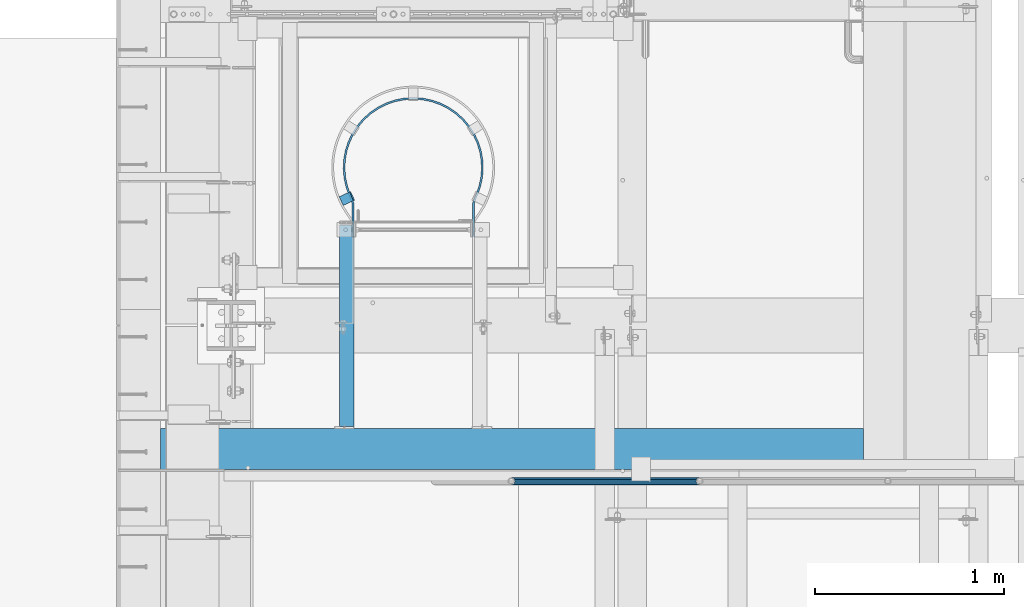
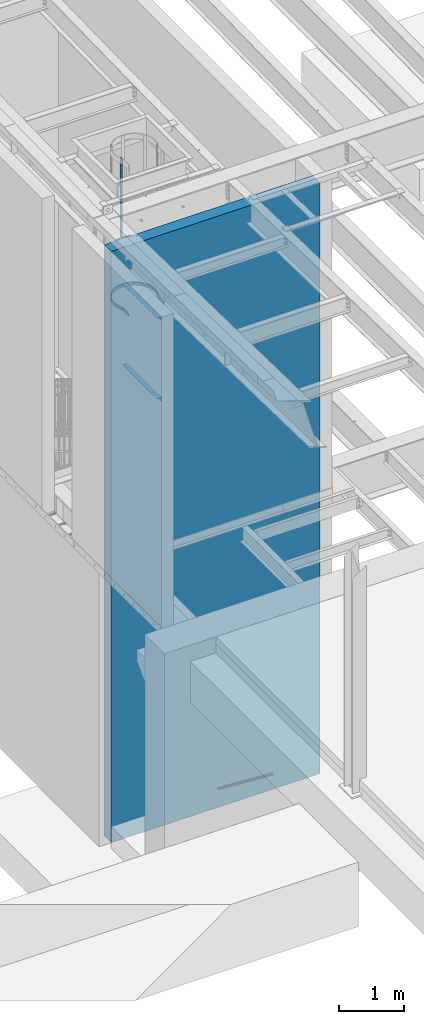
# One storey, part 1077 of 1763: 7 beams, 3 elements without a shape of their own.
"""IFC2X3 building model written with IfcOpenShell, lengths in millimetres."""

from ifc_helpers import new_model, si_unit, frame, origin_with_axes, place, context, subcontext, project, spatial, faceted_brep, material, type_object, element, aggregate, save


model = new_model("IFC2X3")

# Units and contexts
model_context = context("Model", 3, precision=1e-05, world=origin_with_axes())
body_context = subcontext(model_context, "Body", "Model", "MODEL_VIEW")
ifc_project = project(units=[si_unit("LENGTHUNIT", "METRE", prefix="MILLI"), si_unit("AREAUNIT", "SQUARE_METRE"), si_unit("VOLUMEUNIT", "CUBIC_METRE"), si_unit("MASSUNIT", "GRAM", prefix="KILO"), si_unit("TIMEUNIT", "SECOND"), si_unit("PLANEANGLEUNIT", "RADIAN"), si_unit("SOLIDANGLEUNIT", "STERADIAN"), si_unit("THERMODYNAMICTEMPERATUREUNIT", "DEGREE_CELSIUS"), si_unit("LUMINOUSINTENSITYUNIT", "LUMEN")], contexts=[model_context])

# Site, building, storey
site_placement = place(None, origin_with_axes())
site = spatial("IfcSite", under=ifc_project, at=site_placement, CompositionType="ELEMENT")
building_placement = place(site_placement, origin_with_axes())
building = spatial("IfcBuilding", under=site, at=building_placement, Name="Undefined", CompositionType="ELEMENT")
storey_placement = place(building_placement, origin_with_axes())
storey = spatial("IfcBuildingStorey", under=building, at=storey_placement, Name="Undefined", CompositionType="ELEMENT", Elevation=0.0)

# Assembly, beam
assembly_1_placement = place(storey_placement, origin_with_axes())
assembly_1 = element("IfcElementAssembly", 1, at=assembly_1_placement, inside=storey, Name="GUARDRAIL", AssemblyPlace="NOTDEFINED", PredefinedType="RIGID_FRAME")
ifc_material_1 = material()
beam_type_1 = type_object("IfcBeamType", PredefinedType="NOTDEFINED")
beam_1_placement = place(assembly_1_placement, frame((-84891.4958692839, 29197.2999999971, 342.725435582883), z_axis=(0.0, -1.0, 0.0), x_axis=(-0.997891522550524, 0.0, 0.0649038459707657)))
beam_1 = element("IfcBeam", 2, at=beam_1_placement, type_object=beam_type_1, material=ifc_material_1, Name="GUARDRAIL", context=body_context, shape_type="Brep", body=[
    faceted_brep([(1000.15019855548, 2.81943357549608e-11, -19.0499999999993), (989.985557506108, 9.5250000000251, -16.4977839420935), (991.224588240293, -9.52499999997053, -16.4977839420935), (982.257505670044, 13.3082123799786, 7.68349999999919), (980.060462398702, 15.3670000000229, 0.0), (979.820916456767, 19.050000000022, 0.0), (982.544523817283, 16.4977839421163, 9.52500000000146), (982.87174965936, 11.46671237998, 9.52500000000146), (982.87174965936, 11.46671237998, -9.52500000000146), (982.544523817283, 16.4977839421163, -9.52500000000146), (982.257505670044, 13.3082123799786, -7.68349999999919), (986.909019565966, 7.68350000002556, -13.3082123799541), (989.47189966141, 2.81943357549608e-11, -15.3669999999984), (987.908504358144, -7.68349999997099, -13.3082123799541), (984.363362158969, -11.4667123799254, -9.52500000000146), (984.690588001031, -16.4977839420635, -9.52500000000146), (983.988664111486, -13.3082123799259, -7.68349999999919), (982.059431983173, -15.3669999999702, 0.0), (982.298977925122, -19.0499999999693, 0.0), (983.988664111486, -13.3082123799259, 7.68349999999919), (984.363362158969, -11.4667123799254, 9.52500000000146), (984.690588001031, -16.4977839420635, 9.52500000000146), (1000.15019855546, 2.72848410531878e-11, 19.0499999999993), (991.224588240293, -9.52499999997053, 16.4977839420935), (989.985557506108, 9.5250000000251, 16.4977839420935), (987.908504358144, -7.68349999997099, 13.3082123799541), (989.47189966141, 2.72848410531878e-11, 15.3669999999984), (986.909019565966, 7.68350000002465, 13.3082123799541), (8.92561031517107, 9.52499999999873, -16.4977839420935), (15.4596105544624, 16.4977839420917, -9.52500000000146), (17.8512206303712, 19.0499999999975, 0.0), (18.0907665723062, 15.3669999999984, 0.0), (15.7868363965099, 11.4667123799545, -9.52500000000146), (16.1615344449092, 13.3082123799541, -7.68349999999919), (16.1615344449092, 13.3082123799541, 7.68349999999919), (15.7868363965099, 11.4667123799545, 9.52500000000146), (15.4596105544624, 16.4977839420917, 9.52500000000146), (8.92561031517107, 9.52499999999873, 16.4977839420935), (1.45519152283669e-11, 1.81898940354586e-12, 19.0499999999993), (10.1646410493704, -9.524999999996, 16.4977839420935), (10.1646410493704, -9.52499999999509, -16.4977839420935), (1.45519152283669e-11, 1.81898940354586e-12, -19.0499999999993), (17.6056747381954, -16.4977839420881, -9.52500000000146), (20.3292820987263, -19.0499999999938, 0.0), (17.6056747381954, -16.4977839420881, 9.52500000000146), (17.2784488961188, -11.4667123799518, -9.52500000000146), (13.2411789904436, -7.68349999999555, -13.3082123799541), (10.6782988949999, 1.81898940354586e-12, -15.3669999999984), (12.2416941982665, 7.68350000000009, -13.3082123799541), (20.0897361567768, -15.3669999999947, 0.0), (17.8926928863511, -13.3082123799504, -7.68349999999919), (17.2784488961188, -11.4667123799518, 9.52500000000146), (17.8926928863511, -13.3082123799504, 7.68349999999919), (12.2416941982665, 7.68350000000009, 13.3082123799541), (10.6782988949999, 1.81898940354586e-12, 15.3669999999984), (13.2411789904436, -7.68349999999646, 13.3082123799541)], [[[0, 1, 2]], [[3, 4, 5, 6, 7]], [[8, 9, 5, 4, 10]], [[2, 1, 9, 8, 11, 12, 13, 14, 15]], [[15, 14, 16, 17, 18]], [[18, 17, 19, 20, 21]], [[22, 23, 24]], [[21, 20, 25, 26, 27, 7, 6, 24, 23]], [[9, 1, 28, 29]], [[5, 9, 29, 30]], [[31, 30, 29, 32, 33]], [[34, 35, 36, 30, 31]], [[6, 5, 30, 36]], [[24, 6, 36, 37]], [[22, 24, 37, 38]], [[38, 37, 39]], [[0, 2, 40, 41]], [[2, 15, 42, 40]], [[15, 18, 43, 42]], [[18, 21, 44, 43]], [[21, 23, 39, 44]], [[23, 22, 38, 39]], [[1, 0, 41, 28]], [[40, 28, 41]], [[42, 45, 46, 47, 48, 32, 29, 28, 40]], [[43, 49, 50, 45, 42]], [[44, 51, 52, 49, 43]], [[39, 37, 36, 35, 53, 54, 55, 51, 44]], [[26, 25, 55, 54]], [[55, 25, 20, 19, 52, 51]], [[19, 17, 49, 52]], [[17, 16, 50, 49]], [[16, 14, 13, 46, 45, 50]], [[13, 12, 47, 46]], [[12, 11, 48, 47]], [[48, 11, 8, 10, 33, 32]], [[10, 4, 31, 33]], [[4, 3, 34, 31]], [[3, 7, 27, 53, 35, 34]], [[27, 26, 54, 53]]]),
])
aggregate(assembly_1, [beam_1])

# Assembly, beams
assembly_2_placement = place(storey_placement, origin_with_axes())
assembly_2 = element("IfcElementAssembly", 3, at=assembly_2_placement, inside=storey, Name="LADDER", AssemblyPlace="NOTDEFINED", PredefinedType="RIGID_FRAME")
ifc_material_2 = material(Name="STEEL/A36")
beam_type_2 = type_object("IfcBeamType", Name="L3X3X1/4", PredefinedType="NOTDEFINED")
beam_2_placement = place(assembly_2_placement, frame((-86762.6624669171, 30556.2000060747, 9410.7), z_axis=(-1.0, 0.0, 0.0), x_axis=(0.0, -1.0, 0.0)))
beam_2 = element("IfcBeam", 4, at=beam_2_placement, type_object=beam_type_2, material=ifc_material_2, Name="ANGLE", ObjectType="L3X3X1/4", context=body_context, shape_type="Brep", body=[
    faceted_brep([(0.0, 38.0999999999985, -38.1000000000004), (0.0, 38.0999999999985, 38.1000000000004), (1069.97500607761, 38.1000000000004, 38.1000000000058), (1069.97500607761, 38.1000000000004, -38.1000000000058), (0.0, 31.75, 38.1000000000058), (1069.97500607761, 31.75, 38.1000000000058), (0.0, 31.75, -31.75), (1069.97500607761, 31.75, -31.75), (0.0, -38.1000000000004, -31.75), (1069.97500607761, -38.1000000000004, -31.75), (0.0, -38.0999999999985, -38.1000000000004), (1069.97500607761, -38.1000000000004, -38.1000000000058)], [[[0, 1, 2, 3]], [[1, 4, 5, 2]], [[4, 6, 7, 5]], [[6, 8, 9, 7]], [[8, 10, 11, 9]], [[10, 0, 3, 11]], [[5, 7, 9, 11, 3, 2]], [[10, 8, 6, 4, 1, 0]]]),
])
beam_3_placement = place(assembly_2_placement, frame((-86762.6624669171, 30556.2000060747, 7886.70000005696), z_axis=(-1.0, 0.0, 0.0), x_axis=(0.0, -1.0, 0.0)))
beam_3 = element("IfcBeam", 5, at=beam_3_placement, type_object=beam_type_2, material=ifc_material_2, Name="ANGLE", ObjectType="L3X3X1/4", context=body_context, shape_type="Brep", body=[
    faceted_brep([(0.0, 38.0999999999985, -38.1000000000004), (0.0, 38.0999999999985, 38.1000000000004), (1069.97500607761, 38.1000000000004, 38.1000000000058), (1069.97500607761, 38.1000000000004, -38.1000000000058), (0.0, 31.75, 38.1000000000058), (1069.97500607761, 31.75, 38.1000000000058), (0.0, 31.75, -31.75), (1069.97500607761, 31.75, -31.75), (0.0, -38.1000000000004, -31.75), (1069.97500607761, -38.1000000000004, -31.75), (0.0, -38.0999999999985, -38.1000000000004), (1069.97500607761, -38.1000000000004, -38.1000000000058)], [[[0, 1, 2, 3]], [[1, 4, 5, 2]], [[4, 6, 7, 5]], [[6, 8, 9, 7]], [[8, 10, 11, 9]], [[10, 0, 3, 11]], [[5, 7, 9, 11, 3, 2]], [[10, 8, 6, 4, 1, 0]]]),
])
beam_type_3 = type_object("IfcBeamType", PredefinedType="NOTDEFINED")
beam_4_placement = place(assembly_2_placement, frame((-86789.3779025073, 30684.2038212696, 7620.0), z_axis=(0.422618261967727, -0.906307786930785, 0.0), x_axis=(0.0, 0.0, 1.0)))
beam_4 = element("IfcBeam", 6, at=beam_4_placement, type_object=beam_type_3, material=ifc_material_2, Name="PLATE", context=body_context, shape_type="Brep", body=[
    faceted_brep([(0.0, -3.17500000017753, -25.4000000001233), (0.0, -3.17499999987194, 25.4000000001051), (0.0, 3.17500000014843, 25.4000000001197), (0.0, 3.17499999984284, -25.4000000001088), (76.1999969380622, 3.17500000014843, 25.4000000001197), (76.1999969380695, 3.17499999984284, -25.4000000001088), (76.0331158036188, -3.17500000017753, -25.4000000001197), (76.0331158036115, -3.17499999987194, 25.4000000001051), (1225.55004882846, -57.2777259409777, 25.400000000287), (1225.55004882847, -57.2777259412833, -25.3999999999487), (1225.38316769402, -63.6277259413182, -25.3999999999633), (1225.38316769401, -63.6277259410126, 25.4000000002725), (4092.07739257812, -57.2777259409631, 25.4000000002798), (4092.07739257812, -57.2777259412833, -25.399999999956), (4092.07739257812, -63.6277259410126, 25.4000000002652), (4092.07739257812, -63.6277259413182, -25.3999999999705)], [[[0, 1, 2, 3]], [[3, 2, 4, 5]], [[1, 0, 6, 7]], [[5, 4, 8, 9]], [[7, 6, 10, 11]], [[9, 8, 12, 13]], [[8, 4, 2, 1, 7, 11, 14, 12]], [[11, 10, 15, 14]], [[10, 6, 0, 3, 5, 9, 13, 15]], [[14, 15, 13, 12]]]),
])
beam_type_4 = type_object("IfcBeamType", PredefinedType="NOTDEFINED")
beam_5_placement = place(assembly_2_placement, frame((-86091.1497736991, 30492.7, 9761.28873111828), z_axis=(0.0, 0.0, 1.0), x_axis=(0.0, 1.0, 0.0)))
beam_5 = element("IfcBeam", 7, at=beam_5_placement, type_object=beam_type_4, material=ifc_material_2, Name="PLATE", context=body_context, shape_type="Brep", body=[
    faceted_brep([(0.0, -4.76249999999709, -31.75), (0.0, -4.76250000000073, 31.75), (0.0, 4.76250000000073, 31.75), (0.0, 4.76249999999709, -31.75), (178.996850182604, 4.76249999999709, 31.75), (178.996850182604, 4.76249999999709, -31.75), (177.198920081068, -4.76249999999709, -31.75), (177.198920081068, -4.76249999999709, 31.75), (223.923672469686, -12.8248261728149, 31.75), (223.923672469686, -12.8248261728149, -31.75), (220.301876254001, -21.6358444885554, -31.75), (220.301876254001, -21.6358444885554, 31.75), (225.062862920662, -13.315718922473, 31.75), (225.062862920662, -13.315718922473, -31.75), (221.293479549164, -22.0631399137492, -31.75), (221.293479549164, -22.0631399137492, 31.75), (268.797622331076, -28.9179700700479, 31.75), (268.797622331076, -28.9179700700479, -31.75), (266.179279316701, -38.0760214380571, -31.75), (266.179279316701, -38.0760214380571, 31.75), (312.745907862791, -48.2099496661976, -31.75), (312.745907862791, -48.2099496661976, 31.75), (314.170107762209, -38.7920263469859, 31.75), (314.170241653486, -38.7920465962816, -31.75), (361.121282329259, -42.7913046950562, 31.75), (361.121282318767, -42.7913046948524, -31.75), (360.932367573077, -52.3144310837524, -31.75), (360.932367573077, -52.3144310837524, 31.75), (408.553266824139, -40.6172059538658, 31.75), (408.55326734237, -40.6172058958764, -31.75), (409.612565695392, -50.0831190583413, -31.75), (409.612565695392, -50.0831190583413, 31.75), (455.29255648837, -32.2529272571555, 31.75), (455.292556022912, -32.2529273724067, -31.75), (457.581833160064, -41.4987283214577, -31.75), (457.581833160064, -41.4987283214577, 31.75), (500.534787634006, -17.8424056936346, 31.75), (500.534787766108, -17.8424056417862, -31.75), (504.014650842557, -26.7089820932306, -31.75), (504.014650842557, -26.7089820932306, 31.75), (543.501358126799, 2.36636306563742, 31.75), (543.501358463509, 2.36636325190193, -31.75), (548.111923123197, -5.96840240281017, -31.75), (548.111923123197, -5.96840240281017, 31.75), (584.009198027747, 28.437626318133, 31.75), (584.009196713676, 28.4376253428782, -31.75), (589.685748261316, 20.7889399965643, -31.75), (589.685748261316, 20.7889399965643, 31.75), (620.696023637076, 59.6572758920083, 31.75), (620.696025797544, 59.6572779939015, -31.75), (627.338033980115, 52.8301737539878, -31.75), (627.338033980115, 52.8301737539878, 31.75), (652.912087062563, 95.4723277354788, 31.75), (652.91208579253, 95.4723261190084, -31.75), (660.401877781187, 89.5877155994822, -31.75), (660.401877781187, 89.5877155994822, 31.75), (680.086755434721, 135.248364146639, 31.75), (680.086754505715, 135.248362571074, -31.75), (688.291662534022, 130.410479847502, -31.75), (688.291662534022, 130.410479847502, 31.75), (701.738563283165, 178.280798617299, 31.75), (701.73856488548, 178.280802411682, -31.75), (710.513267771523, 174.575372037012, -31.75), (710.513267771523, 174.575372037012, 31.75), (717.484088221368, 223.807419031116, 31.75), (717.484087259192, 223.80741550494, -31.75), (726.673138341132, 221.300033361462, -31.75), (726.673138341132, 221.300033361462, 31.75), (727.044327443258, 271.021749271633, 31.75), (727.044327941214, 271.021752988236, -31.75), (736.484969431742, 269.756876216648, -31.75), (736.484969431742, 269.756876216648, 31.75), (730.250012207038, 319.087498404828, 31.75), (730.250012207031, 319.087495313172, -31.75), (739.775012207032, 319.087489388141, -31.75), (739.775012207032, 319.087489388141, 31.75), (727.044328675405, 367.153259842584, 31.75), (727.044328513592, 367.153261050305, -31.75), (736.484968199595, 368.418151290229, -31.75), (736.484968199595, 368.418151290229, 31.75), (717.484085293047, 414.367594752388, 31.75), (717.484085562104, 414.367593766336, -31.75), (726.673141269457, 416.87495895855, -31.75), (726.673141269457, 416.87495895855, 31.75), (701.738568815384, 459.894191333835, 31.75), (701.738567727607, 459.894193909757, -31.75), (710.513262239299, 463.599644115384, -31.75), (710.513262239299, 463.599644115384, 31.75), (680.086748702986, 502.926650321984, 31.75), (680.086750557224, 502.926647177228, -31.75), (688.29166926576, 507.764511787405, -31.75), (688.29166926576, 507.764511787405, 31.75), (652.912093282088, 542.702644512043, 31.75), (652.912090596754, 542.702647929866, -31.75), (660.401871561658, 548.58727248013, -31.75), (660.401871561658, 548.58727248013, 31.75), (620.696019913037, 578.51772696813, 31.75), (620.696024247423, 578.517722751247, -31.75), (627.338037704154, 585.344821859995, -31.75), (627.338037704154, 585.344821859995, 31.75), (584.009197168081, 609.737364020199, 31.75), (584.009193942664, 609.737366413974, -31.75), (589.685749120978, 617.386049065753, -31.75), (589.685749120978, 617.386049065753, 31.75), (543.501362367231, 635.808628103681, 31.75), (543.501361835584, 635.808628397775, -31.75), (548.111918882772, 644.143398263506, -31.75), (548.111918882772, 644.143398263506, 31.75), (500.534784456919, 656.017396640862, 31.75), (500.534786494096, 656.017395841336, -31.75), (504.014654019651, 664.883970546623, -31.75), (504.014654019651, 664.883970546623, 31.75), (455.292552670799, 670.427942698254, 31.75), (455.292552716117, 670.427942687034, -31.75), (457.581836977639, 679.673741872059, -31.75), (457.581836977639, 679.673741872059, 31.75), (408.553277115458, 678.792188780484, 31.75), (408.553273513717, 678.792189183543, -31.75), (409.61255540407, 688.258104188266, -31.75), (409.61255540407, 688.258104188266, 31.75), (361.121277097478, 680.966280940163, 31.75), (361.12128097919, 680.966281017158, -31.75), (360.932372804862, 690.489407536414, -31.75), (360.932372804862, 690.489407536414, 31.75), (314.170242988643, 676.96702314711, 31.75), (314.170241809003, 676.967022968674, -31.75), (312.745772636365, 686.384905563842, -31.75), (312.745772636365, 686.384905563842, 31.75), (268.136629496974, 666.902248529776, 31.75), (268.136630694469, 666.902248874627, -31.75), (265.500760639741, 676.055271001474, -31.75), (265.500760639741, 676.055271001474, 31.75), (225.062605304862, 651.49063320244, 31.75), (225.062857896504, 651.490742038819, -31.75), (221.29373196304, 660.238273954848, -31.75), (221.29373196304, 660.238273954848, 31.75), (223.92367006966, 650.999851168279, 31.75), (223.92367006966, 650.999851168279, -31.75), (220.301873029875, 659.81086903195, -31.75), (220.301873029875, 659.81086903195, 31.75), (178.996852032531, 633.412487792972, 31.75), (178.996852032531, 633.412487792972, -31.75), (177.198918231141, 642.937487792966, -31.75), (177.198918231141, 642.937487792966, 31.75), (0.0, 633.412487792972, 31.75), (0.0, 633.412487792972, -31.75), (0.0, 642.937487792966, 31.75), (0.0, 642.937487792966, -31.75)], [[[0, 1, 2, 3]], [[3, 2, 4, 5]], [[1, 0, 6, 7]], [[5, 4, 8, 9]], [[7, 6, 10, 11]], [[9, 8, 12, 13]], [[11, 10, 14, 15]], [[13, 12, 16, 17]], [[15, 14, 18, 19]], [[18, 20, 21, 19]], [[16, 22, 23, 17]], [[23, 22, 24, 25]], [[21, 20, 26, 27]], [[25, 24, 28, 29]], [[27, 26, 30, 31]], [[29, 28, 32, 33]], [[31, 30, 34, 35]], [[33, 32, 36, 37]], [[35, 34, 38, 39]], [[37, 36, 40, 41]], [[39, 38, 42, 43]], [[41, 40, 44, 45]], [[43, 42, 46, 47]], [[45, 44, 48, 49]], [[47, 46, 50, 51]], [[49, 48, 52, 53]], [[51, 50, 54, 55]], [[53, 52, 56, 57]], [[55, 54, 58, 59]], [[57, 56, 60, 61]], [[59, 58, 62, 63]], [[61, 60, 64, 65]], [[63, 62, 66, 67]], [[65, 64, 68, 69]], [[67, 66, 70, 71]], [[69, 68, 72, 73]], [[71, 70, 74, 75]], [[73, 72, 76, 77]], [[75, 74, 78, 79]], [[77, 76, 80, 81]], [[79, 78, 82, 83]], [[81, 80, 84, 85]], [[83, 82, 86, 87]], [[85, 84, 88, 89]], [[87, 86, 90, 91]], [[89, 88, 92, 93]], [[91, 90, 94, 95]], [[93, 92, 96, 97]], [[95, 94, 98, 99]], [[97, 96, 100, 101]], [[99, 98, 102, 103]], [[101, 100, 104, 105]], [[103, 102, 106, 107]], [[105, 104, 108, 109]], [[107, 106, 110, 111]], [[109, 108, 112, 113]], [[111, 110, 114, 115]], [[113, 112, 116, 117]], [[115, 114, 118, 119]], [[117, 116, 120, 121]], [[119, 118, 122, 123]], [[121, 120, 124, 125]], [[123, 122, 126, 127]], [[125, 124, 128, 129]], [[127, 126, 130, 131]], [[129, 128, 132, 133]], [[131, 130, 134, 135]], [[133, 132, 136, 137]], [[135, 134, 138, 139]], [[137, 136, 140, 141]], [[139, 138, 142, 143]], [[141, 140, 144, 145]], [[140, 136, 132, 128, 124, 120, 116, 112, 108, 104, 100, 96, 92, 88, 84, 80, 76, 72, 68, 64, 60, 56, 52, 48, 44, 40, 36, 32, 28, 24, 22, 16, 12, 8, 4, 2, 1, 7, 11, 15, 19, 21, 27, 31, 35, 39, 43, 47, 51, 55, 59, 63, 67, 71, 75, 79, 83, 87, 91, 95, 99, 103, 107, 111, 115, 119, 123, 127, 131, 135, 139, 143, 146, 144]], [[143, 142, 147, 146]], [[142, 138, 134, 130, 126, 122, 118, 114, 110, 106, 102, 98, 94, 90, 86, 82, 78, 74, 70, 66, 62, 58, 54, 50, 46, 42, 38, 34, 30, 26, 20, 18, 14, 10, 6, 0, 3, 5, 9, 13, 17, 23, 25, 29, 33, 37, 41, 45, 49, 53, 57, 61, 65, 69, 73, 77, 81, 85, 89, 93, 97, 101, 105, 109, 113, 117, 121, 125, 129, 133, 137, 141, 145, 147]], [[146, 147, 145, 144]]]),
])
beam_6_placement = place(assembly_2_placement, frame((-86091.1497736991, 30492.7, 8877.3), z_axis=(0.0, 0.0, 1.0), x_axis=(0.0, 1.0, 0.0)))
beam_6 = element("IfcBeam", 8, at=beam_6_placement, type_object=beam_type_4, material=ifc_material_2, Name="PLATE", context=body_context, shape_type="Brep", body=[
    faceted_brep([(0.0, -4.76249999999709, -31.75), (0.0, -4.76250000000073, 31.75), (0.0, 4.76250000000073, 31.75), (0.0, 4.76249999999709, -31.75), (178.996850182604, 4.76249999999709, 31.75), (178.996850182604, 4.76249999999709, -31.75), (177.198920081068, -4.76249999999709, -31.75), (177.198920081068, -4.76249999999709, 31.75), (223.923672469686, -12.8248261728149, 31.75), (223.923672469686, -12.8248261728149, -31.75), (220.301876254001, -21.6358444885554, -31.75), (220.301876254001, -21.6358444885554, 31.75), (225.062862920662, -13.315718922473, 31.75), (225.062862920662, -13.315718922473, -31.75), (221.293479549164, -22.0631399137492, -31.75), (221.293479549164, -22.0631399137492, 31.75), (268.797622331076, -28.9179700700479, 31.75), (268.797622331076, -28.9179700700479, -31.75), (266.179279316701, -38.0760214380571, -31.75), (266.179279316701, -38.0760214380571, 31.75), (312.745907862791, -48.2099496661976, -31.75), (312.745907862791, -48.2099496661976, 31.75), (314.170107762209, -38.7920263469859, 31.75), (314.170241653486, -38.7920465962816, -31.75), (361.121282329259, -42.7913046950562, 31.75), (361.121282318767, -42.7913046948524, -31.75), (360.932367573077, -52.3144310837524, -31.75), (360.932367573077, -52.3144310837524, 31.75), (408.553266824139, -40.6172059538658, 31.75), (408.55326734237, -40.6172058958764, -31.75), (409.612565695392, -50.0831190583413, -31.75), (409.612565695392, -50.0831190583413, 31.75), (455.29255648837, -32.2529272571555, 31.75), (455.292556022912, -32.2529273724067, -31.75), (457.581833160064, -41.4987283214577, -31.75), (457.581833160064, -41.4987283214577, 31.75), (500.534787634006, -17.8424056936346, 31.75), (500.534787766108, -17.8424056417862, -31.75), (504.014650842557, -26.7089820932306, -31.75), (504.014650842557, -26.7089820932306, 31.75), (543.501358126799, 2.36636306563742, 31.75), (543.501358463509, 2.36636325190193, -31.75), (548.111923123197, -5.96840240281017, -31.75), (548.111923123197, -5.96840240281017, 31.75), (584.009198027747, 28.437626318133, 31.75), (584.009196713676, 28.4376253428782, -31.75), (589.685748261316, 20.7889399965643, -31.75), (589.685748261316, 20.7889399965643, 31.75), (620.696023637076, 59.6572758920083, 31.75), (620.696025797544, 59.6572779939015, -31.75), (627.338033980115, 52.8301737539878, -31.75), (627.338033980115, 52.8301737539878, 31.75), (652.912087062563, 95.4723277354788, 31.75), (652.91208579253, 95.4723261190084, -31.75), (660.401877781187, 89.5877155994822, -31.75), (660.401877781187, 89.5877155994822, 31.75), (680.086755434721, 135.248364146639, 31.75), (680.086754505715, 135.248362571074, -31.75), (688.291662534022, 130.410479847502, -31.75), (688.291662534022, 130.410479847502, 31.75), (701.738563283165, 178.280798617299, 31.75), (701.73856488548, 178.280802411682, -31.75), (710.513267771523, 174.575372037012, -31.75), (710.513267771523, 174.575372037012, 31.75), (717.484088221368, 223.807419031116, 31.75), (717.484087259192, 223.80741550494, -31.75), (726.673138341132, 221.300033361462, -31.75), (726.673138341132, 221.300033361462, 31.75), (727.044327443258, 271.021749271633, 31.75), (727.044327941214, 271.021752988236, -31.75), (736.484969431742, 269.756876216648, -31.75), (736.484969431742, 269.756876216648, 31.75), (730.250012207038, 319.087498404828, 31.75), (730.250012207031, 319.087495313172, -31.75), (739.775012207032, 319.087489388141, -31.75), (739.775012207032, 319.087489388141, 31.75), (727.044328675405, 367.153259842584, 31.75), (727.044328513592, 367.153261050305, -31.75), (736.484968199595, 368.418151290229, -31.75), (736.484968199595, 368.418151290229, 31.75), (717.484085293047, 414.367594752388, 31.75), (717.484085562104, 414.367593766336, -31.75), (726.673141269457, 416.87495895855, -31.75), (726.673141269457, 416.87495895855, 31.75), (701.738568815384, 459.894191333835, 31.75), (701.738567727607, 459.894193909757, -31.75), (710.513262239299, 463.599644115384, -31.75), (710.513262239299, 463.599644115384, 31.75), (680.086748702986, 502.926650321984, 31.75), (680.086750557224, 502.926647177228, -31.75), (688.29166926576, 507.764511787405, -31.75), (688.29166926576, 507.764511787405, 31.75), (652.912093282088, 542.702644512043, 31.75), (652.912090596754, 542.702647929866, -31.75), (660.401871561658, 548.58727248013, -31.75), (660.401871561658, 548.58727248013, 31.75), (620.696019913037, 578.51772696813, 31.75), (620.696024247423, 578.517722751247, -31.75), (627.338037704154, 585.344821859995, -31.75), (627.338037704154, 585.344821859995, 31.75), (584.009197168081, 609.737364020199, 31.75), (584.009193942664, 609.737366413974, -31.75), (589.685749120978, 617.386049065753, -31.75), (589.685749120978, 617.386049065753, 31.75), (543.501362367231, 635.808628103681, 31.75), (543.501361835584, 635.808628397775, -31.75), (548.111918882772, 644.143398263506, -31.75), (548.111918882772, 644.143398263506, 31.75), (500.534784456919, 656.017396640862, 31.75), (500.534786494096, 656.017395841336, -31.75), (504.014654019651, 664.883970546623, -31.75), (504.014654019651, 664.883970546623, 31.75), (455.292552670799, 670.427942698254, 31.75), (455.292552716117, 670.427942687034, -31.75), (457.581836977639, 679.673741872059, -31.75), (457.581836977639, 679.673741872059, 31.75), (408.553277115458, 678.792188780484, 31.75), (408.553273513717, 678.792189183543, -31.75), (409.61255540407, 688.258104188266, -31.75), (409.61255540407, 688.258104188266, 31.75), (361.121277097478, 680.966280940163, 31.75), (361.12128097919, 680.966281017158, -31.75), (360.932372804862, 690.489407536414, -31.75), (360.932372804862, 690.489407536414, 31.75), (314.170242988643, 676.96702314711, 31.75), (314.170241809003, 676.967022968674, -31.75), (312.745772636365, 686.384905563842, -31.75), (312.745772636365, 686.384905563842, 31.75), (268.136629496974, 666.902248529776, 31.75), (268.136630694469, 666.902248874627, -31.75), (265.500760639741, 676.055271001474, -31.75), (265.500760639741, 676.055271001474, 31.75), (225.062605304862, 651.49063320244, 31.75), (225.062857896504, 651.490742038819, -31.75), (221.29373196304, 660.238273954848, -31.75), (221.29373196304, 660.238273954848, 31.75), (223.92367006966, 650.999851168279, 31.75), (223.92367006966, 650.999851168279, -31.75), (220.301873029875, 659.81086903195, -31.75), (220.301873029875, 659.81086903195, 31.75), (178.996852032531, 633.412487792972, 31.75), (178.996852032531, 633.412487792972, -31.75), (177.198918231141, 642.937487792966, -31.75), (177.198918231141, 642.937487792966, 31.75), (0.0, 633.412487792972, 31.75), (0.0, 633.412487792972, -31.75), (0.0, 642.937487792966, 31.75), (0.0, 642.937487792966, -31.75)], [[[0, 1, 2, 3]], [[3, 2, 4, 5]], [[1, 0, 6, 7]], [[5, 4, 8, 9]], [[7, 6, 10, 11]], [[9, 8, 12, 13]], [[11, 10, 14, 15]], [[13, 12, 16, 17]], [[15, 14, 18, 19]], [[18, 20, 21, 19]], [[16, 22, 23, 17]], [[23, 22, 24, 25]], [[21, 20, 26, 27]], [[25, 24, 28, 29]], [[27, 26, 30, 31]], [[29, 28, 32, 33]], [[31, 30, 34, 35]], [[33, 32, 36, 37]], [[35, 34, 38, 39]], [[37, 36, 40, 41]], [[39, 38, 42, 43]], [[41, 40, 44, 45]], [[43, 42, 46, 47]], [[45, 44, 48, 49]], [[47, 46, 50, 51]], [[49, 48, 52, 53]], [[51, 50, 54, 55]], [[53, 52, 56, 57]], [[55, 54, 58, 59]], [[57, 56, 60, 61]], [[59, 58, 62, 63]], [[61, 60, 64, 65]], [[63, 62, 66, 67]], [[65, 64, 68, 69]], [[67, 66, 70, 71]], [[69, 68, 72, 73]], [[71, 70, 74, 75]], [[73, 72, 76, 77]], [[75, 74, 78, 79]], [[77, 76, 80, 81]], [[79, 78, 82, 83]], [[81, 80, 84, 85]], [[83, 82, 86, 87]], [[85, 84, 88, 89]], [[87, 86, 90, 91]], [[89, 88, 92, 93]], [[91, 90, 94, 95]], [[93, 92, 96, 97]], [[95, 94, 98, 99]], [[97, 96, 100, 101]], [[99, 98, 102, 103]], [[101, 100, 104, 105]], [[103, 102, 106, 107]], [[105, 104, 108, 109]], [[107, 106, 110, 111]], [[109, 108, 112, 113]], [[111, 110, 114, 115]], [[113, 112, 116, 117]], [[115, 114, 118, 119]], [[117, 116, 120, 121]], [[119, 118, 122, 123]], [[121, 120, 124, 125]], [[123, 122, 126, 127]], [[125, 124, 128, 129]], [[127, 126, 130, 131]], [[129, 128, 132, 133]], [[131, 130, 134, 135]], [[133, 132, 136, 137]], [[135, 134, 138, 139]], [[137, 136, 140, 141]], [[139, 138, 142, 143]], [[141, 140, 144, 145]], [[140, 136, 132, 128, 124, 120, 116, 112, 108, 104, 100, 96, 92, 88, 84, 80, 76, 72, 68, 64, 60, 56, 52, 48, 44, 40, 36, 32, 28, 24, 22, 16, 12, 8, 4, 2, 1, 7, 11, 15, 19, 21, 27, 31, 35, 39, 43, 47, 51, 55, 59, 63, 67, 71, 75, 79, 83, 87, 91, 95, 99, 103, 107, 111, 115, 119, 123, 127, 131, 135, 139, 143, 146, 144]], [[143, 142, 147, 146]], [[142, 138, 134, 130, 126, 122, 118, 114, 110, 106, 102, 98, 94, 90, 86, 82, 78, 74, 70, 66, 62, 58, 54, 50, 46, 42, 38, 34, 30, 26, 20, 18, 14, 10, 6, 0, 3, 5, 9, 13, 17, 23, 25, 29, 33, 37, 41, 45, 49, 53, 57, 61, 65, 69, 73, 77, 81, 85, 89, 93, 97, 101, 105, 109, 113, 117, 121, 125, 129, 133, 137, 141, 145, 147]], [[146, 147, 145, 144]]]),
])
aggregate(assembly_2, [beam_2, beam_3, beam_5, beam_4, beam_6])

# Assembly, beam
assembly_3_placement = place(storey_placement, origin_with_axes())
assembly_3 = element("IfcElementAssembly", 9, at=assembly_3_placement, inside=storey, Name="WALL", AssemblyPlace="NOTDEFINED", PredefinedType="REINFORCEMENT_UNIT")
ifc_material_3 = material(Name="CONCRETE/5000")
beam_type_5 = type_object("IfcBeamType", PredefinedType="NOTDEFINED")
beam_7_placement = place(assembly_3_placement, frame((-87750.0872736983, 29368.7499999971, 5588.0), z_axis=(0.0, 1.0, 0.0), x_axis=(1.0, 0.0, 0.0)))
beam_7 = element("IfcBeam", 10, at=beam_7_placement, type_object=beam_type_5, material=ifc_material_3, Name="WALL", context=body_context, shape_type="Brep", body=[
    faceted_brep([(0.0, 5588.0, -107.949999999997), (0.0, 5588.0, 107.949999999997), (3727.45, 5588.0, 107.949999999997), (3727.45, 5588.0, -107.949999999997), (0.0, -5588.0, 107.949999999997), (3727.45, -5588.0, 107.949999999997), (0.0, -5588.0, -107.949999999997), (3727.45, -5588.0, -107.949999999997)], [[[0, 1, 2, 3]], [[1, 4, 5, 2]], [[4, 6, 7, 5]], [[6, 0, 3, 7]], [[5, 7, 3, 2]], [[6, 4, 1, 0]]]),
])
aggregate(assembly_3, [beam_7])

save(model, "model.ifc")
